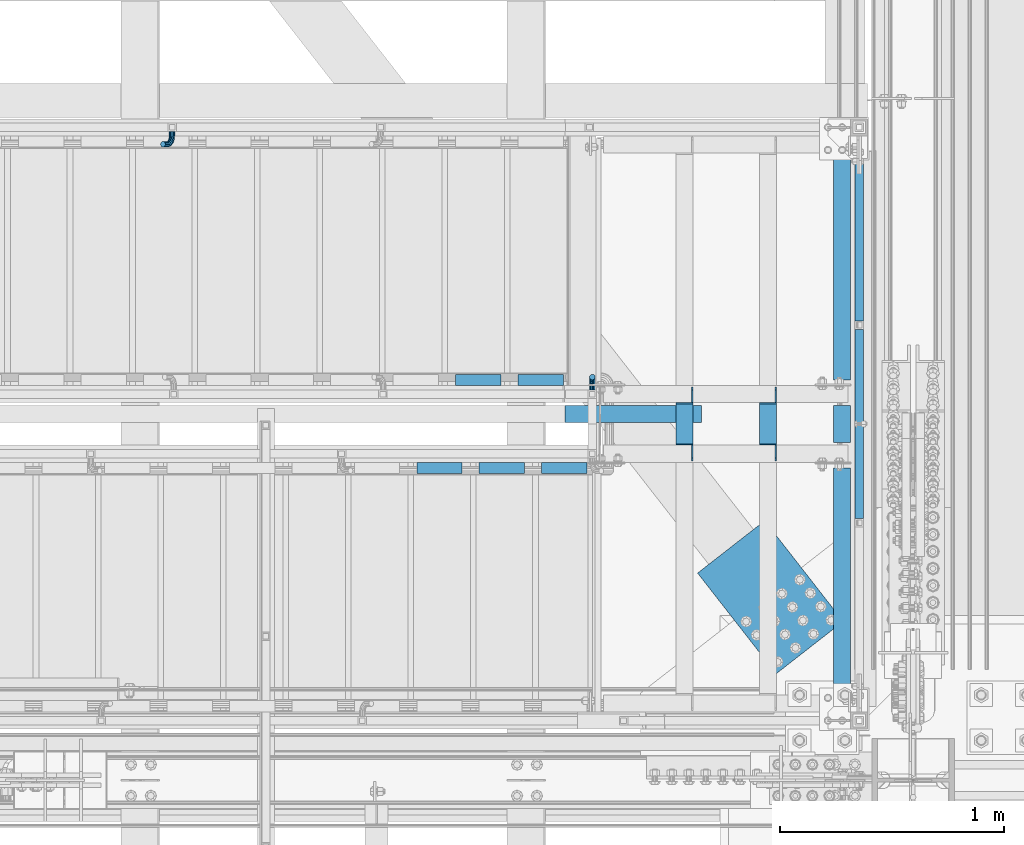
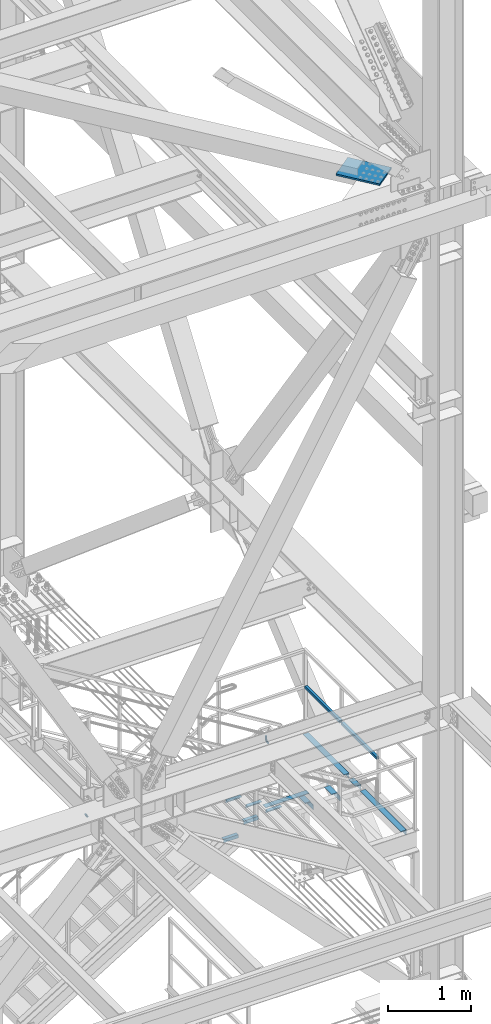
# One storey, part 2588 of 3843: 16 beams, 10 elements without a shape of their own.
"""IFC2X3 building model written with IfcOpenShell, lengths in millimetres."""

from ifc_helpers import new_model, si_unit, frame, origin_with_axes, place, context, subcontext, project, spatial, faceted_brep, material, type_object, element, aggregate, save


model = new_model("IFC2X3")

# Units and contexts
model_context = context("Model", 3, precision=1e-05, world=origin_with_axes())
body_context = subcontext(model_context, "Body", "Model", "MODEL_VIEW")
ifc_project = project(units=[si_unit("LENGTHUNIT", "METRE", prefix="MILLI"), si_unit("AREAUNIT", "SQUARE_METRE"), si_unit("VOLUMEUNIT", "CUBIC_METRE"), si_unit("MASSUNIT", "GRAM", prefix="KILO"), si_unit("TIMEUNIT", "SECOND"), si_unit("PLANEANGLEUNIT", "RADIAN"), si_unit("SOLIDANGLEUNIT", "STERADIAN"), si_unit("THERMODYNAMICTEMPERATUREUNIT", "DEGREE_CELSIUS"), si_unit("LUMINOUSINTENSITYUNIT", "LUMEN")], contexts=[model_context])

# Site, building, storey
site_placement = place(None, origin_with_axes())
site = spatial("IfcSite", under=ifc_project, at=site_placement, CompositionType="ELEMENT")
building_placement = place(site_placement, origin_with_axes())
building = spatial("IfcBuilding", under=site, at=building_placement, Name="Undefined", CompositionType="ELEMENT")
storey_placement = place(building_placement, origin_with_axes())
storey = spatial("IfcBuildingStorey", under=building, at=storey_placement, Name="Undefined", CompositionType="ELEMENT", Elevation=0.0)

# Assembly, beams
assembly_1_placement = place(storey_placement, origin_with_axes())
assembly_1 = element("IfcElementAssembly", 1, at=assembly_1_placement, inside=storey, Name="RAIL", AssemblyPlace="NOTDEFINED", PredefinedType="RIGID_FRAME")
ifc_material_1 = material()
beam_type_1 = type_object("IfcBeamType", Name="HSS1-1/2X1-1/2X1/4", PredefinedType="NOTDEFINED")
beam_1_placement = place(assembly_1_placement, frame((85407.4999999663, 17034.933333332, 33248.5999999989), z_axis=(0.0, 0.0, 1.0), x_axis=(0.0, 1.0, 0.0)))
beam_1 = element("IfcBeam", 2, at=beam_1_placement, type_object=beam_type_1, material=ifc_material_1, Name="RAIL", ObjectType="HSS1-1/2X1-1/2X1/4", context=body_context, shape_type="Brep", body=[
    faceted_brep([(865.716666687869, -19.0500000104294, 19.0499992350015), (865.716666687869, -19.0499992350015, -19.0499992350015), (865.716666687869, 19.0499992350015, -19.0499992350015), (865.716666687869, 19.0499992518344, 19.0499992350015), (865.716666687869, -12.6999993300014, 12.6999993299978), (865.716666687869, 12.6999993300014, 12.6999993299978), (865.716666687869, 12.6999993300014, -12.6999993299978), (865.716666687869, -12.6999993300014, -12.6999993299978), (19.0499992350015, 19.0499992350015, -19.0499992350015), (19.0499992350015, 19.0499992350015, 19.0499992350015), (19.0499992350015, -19.0499992350015, 19.0499992350015), (19.0499992350015, -19.0499992350015, -19.0499992350015), (19.0499992350015, 12.6999993299978, 12.6999993299978), (19.0499992350015, -12.6999993299978, 12.6999993299978), (19.0499992350015, -12.6999993299978, -12.6999993299978), (19.0499992350015, 12.6999993299978, -12.6999993299978)], [[[0, 1, 2, 3], [4, 5, 6, 7]], [[8, 9, 3, 2]], [[9, 10, 0, 3]], [[10, 11, 1, 0]], [[11, 8, 2, 1]], [[11, 10, 9, 8], [12, 13, 14, 15]], [[14, 13, 4, 7]], [[15, 14, 7, 6]], [[12, 15, 6, 5]], [[13, 12, 5, 4]]]),
])
beam_2_placement = place(assembly_1_placement, frame((85407.4999999681, 16150.1666666695, 33248.5999999989), z_axis=(0.0, 0.0, 1.0), x_axis=(0.0, 1.0, 0.0)))
beam_2 = element("IfcBeam", 3, at=beam_2_placement, type_object=beam_type_1, material=ifc_material_1, Name="RAIL", ObjectType="HSS1-1/2X1-1/2X1/4", context=body_context, shape_type="Brep", body=[
    faceted_brep([(865.716666687869, -19.0500000104294, 19.0499992350015), (865.716666687869, -19.0499992350015, -19.0499992350015), (865.716666687869, 19.0499992350015, -19.0499992350015), (865.716666687869, 19.0499992518344, 19.0499992350015), (865.716666687869, -12.6999993300014, 12.6999993299978), (865.716666687869, 12.6999993300014, 12.6999993299978), (865.716666687869, 12.6999993300014, -12.6999993299978), (865.716666687869, -12.6999993300014, -12.6999993299978), (19.0499992350015, 19.0499992350015, -19.0499992350015), (19.0499992350015, 19.0499992350015, 19.0499992350015), (19.0499992350015, -19.0499992350015, 19.0499992350015), (19.0499992350015, -19.0499992350015, -19.0499992350015), (19.0499992350015, 12.6999993299978, 12.6999993299978), (19.0499992350015, -12.6999993299978, 12.6999993299978), (19.0499992350015, -12.6999993299978, -12.6999993299978), (19.0499992350015, 12.6999993299978, -12.6999993299978)], [[[0, 1, 2, 3], [4, 5, 6, 7]], [[8, 9, 3, 2]], [[9, 10, 0, 3]], [[10, 11, 1, 0]], [[11, 8, 2, 1]], [[11, 10, 9, 8], [12, 13, 14, 15]], [[14, 13, 4, 7]], [[15, 14, 7, 6]], [[12, 15, 6, 5]], [[13, 12, 5, 4]]]),
])
aggregate(assembly_1, [beam_1, beam_2])

# Assembly, beam
assembly_2_placement = place(storey_placement, origin_with_axes())
assembly_2 = element("IfcElementAssembly", 4, at=assembly_2_placement, inside=storey, Name="ref.", AssemblyPlace="NOTDEFINED", PredefinedType="RIGID_FRAME")
ifc_material_2 = material(Name="STEEL/Steel_Undefined")
beam_type_2 = type_object("IfcBeamType", PredefinedType="NOTDEFINED")
beam_3_placement = place(assembly_2_placement, frame((84092.2107283887, 16637.0, 32712.0249999846), z_axis=(0.0, 1.0, 0.0), x_axis=(1.0, 0.0, 0.0)))
beam_3 = element("IfcBeam", 5, at=beam_3_placement, type_object=beam_type_2, material=ifc_material_2, Name="ref.", context=body_context, shape_type="Brep", body=[
    faceted_brep([(0.0, 3.17500000000291, -38.0999999999985), (0.0, 3.17500000000291, 38.0999999999985), (609.600000000006, 3.17499999999927, 38.0999999999985), (609.600000000006, 3.17499999999927, -38.0999999999985), (0.0, -3.17500000000291, 38.0999999999985), (609.600000000006, -3.17499999999927, 38.0999999999985), (0.0, -3.17500000000291, -38.0999999999985), (609.600000000006, -3.17499999999927, -38.0999999999985)], [[[0, 1, 2, 3]], [[1, 4, 5, 2]], [[4, 6, 7, 5]], [[6, 0, 3, 7]], [[5, 7, 3, 2]], [[6, 4, 1, 0]]]),
])
aggregate(assembly_2, [beam_3])

assembly_3_placement = place(storey_placement, origin_with_axes())
assembly_3 = element("IfcElementAssembly", 6, at=assembly_3_placement, inside=storey, Name="STAIR", AssemblyPlace="NOTDEFINED", PredefinedType="RIGID_FRAME")
ifc_material_3 = material(Name="STEEL/A572-50")
beam_type_3 = type_object("IfcBeamType", Name="L2X2X3/16", PredefinedType="NOTDEFINED")
beam_4_placement = place(assembly_3_placement, frame((84084.7140030485, 16789.3999999329, 32463.8865384615), z_axis=(0.0, 1.0, 0.0), x_axis=(-1.0, 0.0, 0.0)))
beam_4 = element("IfcBeam", 7, at=beam_4_placement, type_object=beam_type_3, material=ifc_material_3, Name="ANGLE", ObjectType="L2X2X3/16", context=body_context, shape_type="Brep", body=[
    faceted_brep([(0.0, 25.4000000000015, -25.4000000000015), (0.0, 25.4000000000015, 25.4000000000015), (203.199999999997, 25.4000000000015, 25.4000000000015), (203.199999999997, 25.4000000000015, -25.4000000000015), (0.0, 20.6375000000007, 25.4000000000015), (203.199999999997, 20.6375000000007, 25.4000000000015), (0.0, 20.6375000000007, -20.6375000000007), (203.199999999997, 20.6375000000007, -20.6375000000007), (0.0, -25.4000000000015, -20.6375000000007), (203.199999999997, -25.4000000000015, -20.6375000000007), (0.0, -25.4000000000015, -25.4000000000015), (203.199999999997, -25.4000000000015, -25.4000000000015)], [[[0, 1, 2, 3]], [[1, 4, 5, 2]], [[4, 6, 7, 5]], [[6, 8, 9, 7]], [[8, 10, 11, 9]], [[10, 0, 3, 11]], [[5, 7, 9, 11, 3, 2]], [[10, 8, 6, 4, 1, 0]]]),
])

# Assembly, beams
assembly_4_placement = place(storey_placement, origin_with_axes())
assembly_4 = element("IfcElementAssembly", 8, at=assembly_4_placement, inside=storey, Name="STAIR", AssemblyPlace="NOTDEFINED", PredefinedType="RIGID_FRAME")
ifc_material_4 = material(Name="STEEL/A36")
beam_5_placement = place(assembly_4_placement, frame((83428.2859969491, 16395.700000067, 33151.6403846146), z_axis=(0.0, -1.0, 0.0), x_axis=(1.0, 0.0, 0.0)))
beam_5 = element("IfcBeam", 9, at=beam_5_placement, type_object=beam_type_3, material=ifc_material_4, Name="ANGLE", ObjectType="L2X2X3/16", context=body_context, shape_type="Brep", body=[
    faceted_brep([(0.0, 25.4000000000015, -25.4000000000015), (0.0, 25.4000000000015, 25.4000000000015), (203.199999999997, 25.4000000000015, 25.4000000000015), (203.199999999997, 25.4000000000015, -25.4000000000015), (0.0, 20.6375000000007, 25.4000000000015), (203.199999999997, 20.6375000000007, 25.4000000000015), (0.0, 20.6375000000007, -20.6375000000007), (203.199999999997, 20.6375000000007, -20.6375000000007), (0.0, -25.4000000000015, -20.6375000000007), (203.199999999997, -25.4000000000015, -20.6375000000007), (0.0, -25.4000000000015, -25.4000000000015), (203.199999999997, -25.4000000000015, -25.4000000000015)], [[[0, 1, 2, 3]], [[1, 4, 5, 2]], [[4, 6, 7, 5]], [[6, 8, 9, 7]], [[8, 10, 11, 9]], [[10, 0, 3, 11]], [[5, 7, 9, 11, 3, 2]], [[10, 8, 6, 4, 1, 0]]]),
])
beam_6_placement = place(assembly_4_placement, frame((83707.6859969491, 16395.700000067, 32979.7019230762), z_axis=(0.0, -1.0, 0.0), x_axis=(1.0, 0.0, 0.0)))
beam_6 = element("IfcBeam", 10, at=beam_6_placement, type_object=beam_type_3, material=ifc_material_4, Name="ANGLE", ObjectType="L2X2X3/16", context=body_context, shape_type="Brep", body=[
    faceted_brep([(0.0, 25.4000000000015, -25.4000000000015), (0.0, 25.4000000000015, 25.4000000000015), (203.199999999997, 25.4000000000015, 25.4000000000015), (203.199999999997, 25.4000000000015, -25.4000000000015), (0.0, 20.6375000000007, 25.4000000000015), (203.199999999997, 20.6375000000007, 25.4000000000015), (0.0, 20.6375000000007, -20.6375000000007), (203.199999999997, 20.6375000000007, -20.6375000000007), (0.0, -25.4000000000015, -20.6375000000007), (203.199999999997, -25.4000000000015, -20.6375000000007), (0.0, -25.4000000000015, -25.4000000000015), (203.199999999997, -25.4000000000015, -25.4000000000015)], [[[0, 1, 2, 3]], [[1, 4, 5, 2]], [[4, 6, 7, 5]], [[6, 8, 9, 7]], [[8, 10, 11, 9]], [[10, 0, 3, 11]], [[5, 7, 9, 11, 3, 2]], [[10, 8, 6, 4, 1, 0]]]),
])
beam_7_placement = place(assembly_4_placement, frame((83987.0859969491, 16395.700000067, 32807.7634615377), z_axis=(0.0, -1.0, 0.0), x_axis=(1.0, 0.0, 0.0)))
beam_7 = element("IfcBeam", 11, at=beam_7_placement, type_object=beam_type_3, material=ifc_material_4, Name="ANGLE", ObjectType="L2X2X3/16", context=body_context, shape_type="Brep", body=[
    faceted_brep([(0.0, 25.4000000000015, -25.4000000000015), (0.0, 25.4000000000015, 25.4000000000015), (203.199999999997, 25.4000000000015, 25.4000000000015), (203.199999999997, 25.4000000000015, -25.4000000000015), (0.0, 20.6375000000007, 25.4000000000015), (203.199999999997, 20.6375000000007, 25.4000000000015), (0.0, 20.6375000000007, -20.6375000000007), (203.199999999997, 20.6375000000007, -20.6375000000007), (0.0, -25.4000000000015, -20.6375000000007), (203.199999999997, -25.4000000000015, -20.6375000000007), (0.0, -25.4000000000015, -25.4000000000015), (203.199999999997, -25.4000000000015, -25.4000000000015)], [[[0, 1, 2, 3]], [[1, 4, 5, 2]], [[4, 6, 7, 5]], [[6, 8, 9, 7]], [[8, 10, 11, 9]], [[10, 0, 3, 11]], [[5, 7, 9, 11, 3, 2]], [[10, 8, 6, 4, 1, 0]]]),
])
aggregate(assembly_4, [beam_5, beam_6, beam_7])

# Beam
beam_8_placement = place(assembly_3_placement, frame((83805.3140030504, 16789.3999999318, 32291.9480769222), z_axis=(0.0, 1.0, 0.0), x_axis=(-1.0, 0.0, 0.0)))
beam_8 = element("IfcBeam", 12, at=beam_8_placement, type_object=beam_type_3, material=ifc_material_3, Name="ANGLE", ObjectType="L2X2X3/16", context=body_context, shape_type="Brep", body=[
    faceted_brep([(0.0, 25.4000000000015, -25.4000000000015), (0.0, 25.4000000000015, 25.4000000000015), (203.199999999997, 25.4000000000015, 25.4000000000015), (203.199999999997, 25.4000000000015, -25.4000000000015), (0.0, 20.6375000000007, 25.4000000000015), (203.199999999997, 20.6375000000007, 25.4000000000015), (0.0, 20.6375000000007, -20.6375000000007), (203.199999999997, 20.6375000000007, -20.6375000000007), (0.0, -25.4000000000015, -20.6375000000007), (203.199999999997, -25.4000000000015, -20.6375000000007), (0.0, -25.4000000000015, -25.4000000000015), (203.199999999997, -25.4000000000015, -25.4000000000015)], [[[0, 1, 2, 3]], [[1, 4, 5, 2]], [[4, 6, 7, 5]], [[6, 8, 9, 7]], [[8, 10, 11, 9]], [[10, 0, 3, 11]], [[5, 7, 9, 11, 3, 2]], [[10, 8, 6, 4, 1, 0]]]),
])

aggregate(assembly_3, [beam_4, beam_8])

# Assembly, beam
assembly_5_placement = place(storey_placement, origin_with_axes())
assembly_5 = element("IfcElementAssembly", 13, at=assembly_5_placement, inside=storey, Name="RAIL", AssemblyPlace="NOTDEFINED", PredefinedType="RIGID_FRAME")
beam_type_4 = type_object("IfcBeamType", PredefinedType="NOTDEFINED")
beam_9_placement = place(assembly_5_placement, frame((82332.8664563633, 17900.65, 32430.6618078464), z_axis=(-0.851658316635875, 0.0, -0.524097425775922), x_axis=(0.0, -1.0, 0.0)))
beam_9 = element("IfcBeam", 14, at=beam_9_placement, type_object=beam_type_4, material=ifc_material_4, Name="BRACKET ARM", context=body_context, shape_type="Brep", body=[
    faceted_brep([(0.0, -12.6999999999971, 0.0), (0.0, -10.9985226280696, -6.34999999999854), (19.0500015258731, -10.9985226280623, -6.34999999999854), (19.0500015258731, -12.6999999999971, -6.33008312433958e-10), (0.0, -6.35000000000582, -10.9985226280623), (19.0500015258731, -6.34999999999854, -10.9985226280623), (0.0, 0.0, -12.6999999999971), (19.0500015258731, 0.0, -12.6999999999971), (0.0, 6.35000000000582, -10.9985226280623), (19.0500015258731, 6.34999999999854, -10.9985226280623), (0.0, 10.9985226280696, -6.34999999999854), (19.0500015258731, 10.9985226280623, -6.34999999999854), (0.0, 12.6999999999971, 0.0), (19.0500015258731, 12.6999999999971, 0.0), (0.0, 10.9985226280696, 6.34999999999854), (19.0500015258731, 10.9985226280623, 6.34999999999854), (0.0, 6.35000000000582, 10.9985226280623), (19.0500015258731, 6.34999999999854, 10.9985226280623), (0.0, 0.0, 12.6999999999971), (19.0500015258731, 0.0, 12.6999999999971), (0.0, -6.35000000000582, 10.9985226280623), (19.0500015258731, -6.34999999999854, 10.9985226280623), (0.0, -10.9985226280696, 6.34999999999854), (19.0500015258731, -10.9985226280623, 6.34999999999854), (38.4903193060891, -8.8330803677236, -3.34694050252438e-10), (37.8391921052389, -7.26112024908798, 6.34999999974389), (36.0602795104642, -2.96644533684594, 10.9985226280041), (33.6302397149266, 2.90018969451194, 12.7000000002226), (31.2001999194181, 8.76682472604443, 10.9985226285644), (29.4212873247307, 13.061499638774, 6.35000000070431), (28.7701601240115, 14.6334597580644, 7.78527464717627e-10), (29.4212873248762, 13.0614996394288, -6.34999999929278), (31.2001999196509, 8.76682472718676, -10.9985226275603), (33.6302397151885, 2.90018969582889, -12.6999999997788), (36.0602795106824, -2.96644533571089, -10.9985226281206), (37.8391921053699, -7.26112024843314, -6.35000000026048), (53.7678987435793, 3.38210125690239, -6.3499999994383), (54.9710249311902, 2.17897506880399, 5.0931703299284e-10), (50.4808968708676, 6.66910312997061, -10.9985226273784), (45.9907688103704, 11.1592311906061, -12.6999999991458), (41.5006407498004, 15.6493592510378, -10.9985226270364), (38.213638876914, 18.9363611235749, -6.34999999884167), (37.0105126890558, 20.1394873109457, 1.20053300634027e-09), (38.2136388766667, 18.9363611228473, 6.35000000115542), (41.5006407493784, 15.6493592497718, 10.9985226290883), (45.9907688098756, 11.1592311891436, 12.7000000008557), (50.4808968704456, 6.66910312870459, 10.9985226287463), (53.7678987433319, 3.38210125617479, 6.35000000055879), (64.4111202489148, 19.3108078951118, -6.34999999821594), (65.9830803677178, 18.6596806939051, 1.77533365786076e-09), (60.1164453365491, 21.0897204901557, -10.9985226262725), (54.2498103051475, 23.5197602857806, -12.6999999981927), (48.3831752736587, 25.9498000811873, -10.9985226262434), (44.0885003610601, 27.7287126756128, -6.34999999817228), (42.516540241937, 28.3798398759754, 1.83354131877422e-09), (44.08850036074, 27.7287126747688, 6.35000000183209), (48.3831752731057, 25.9498000797321, 10.9985226298813), (54.2498103045073, 23.5197602840999, 12.7000000018088), (60.1164453359961, 21.0897204886933, 10.9985226298522), (64.4111202485947, 19.3108078942678, 6.35000000178115), (68.1485226282239, 38.0999984746086, -6.3499999967753), (69.8499999999913, 38.0999984741211, 2.92493496090174e-09), (63.500000000291, 38.0999984749651, -10.9985226249628), (57.1500000003434, 38.0999984750961, -12.6999999970722), (50.8000000002939, 38.0999984749651, -10.998522625312), (46.1514773720992, 38.0999984746086, -6.34999999737192), (44.4499999999971, 38.0999984741211, 2.58296495303512e-09), (46.1514773717645, 38.0999984736336, 6.35000000262517), (50.7999999996973, 38.0999984732771, 10.9985226308127), (57.1499999996449, 38.0999984731461, 12.700000002922), (63.4999999996944, 38.0999984732771, 10.9985226311619), (68.1485226278892, 38.0999984736336, 6.35000000322179), (68.1485226280638, 76.2000000002372, -6.34999999414867), (69.8499999999913, 76.199999999757, 5.84986992180347e-09), (63.5, 76.200000000601, -10.9985226222125), (57.1499999999942, 76.2000000007247, -12.6999999941472), (50.7999999999884, 76.200000000601, -10.9985226222125), (46.1514773719246, 76.2000000002372, -6.34999999414867), (44.4499999999971, 76.199999999757, 5.84986992180347e-09), (46.1514773719246, 76.1999999992695, 6.35000000584841), (50.7999999999884, 76.1999999989057, 10.9985226339122), (57.1499999999942, 76.199999998782, 12.700000005847), (63.5, 76.1999999989057, 10.9985226339122), (68.1485226280638, 76.1999999992695, 6.35000000584841)], [[[0, 1, 2, 3]], [[1, 4, 5, 2]], [[4, 6, 7, 5]], [[6, 8, 9, 7]], [[8, 10, 11, 9]], [[10, 12, 13, 11]], [[12, 14, 15, 13]], [[14, 16, 17, 15]], [[16, 18, 19, 17]], [[18, 20, 21, 19]], [[20, 22, 23, 21]], [[22, 0, 3, 23]], [[22, 20, 18, 16, 14, 12, 10, 8, 6, 4, 1, 0]], [[23, 3, 24, 25]], [[21, 23, 25, 26]], [[19, 21, 26, 27]], [[17, 19, 27, 28]], [[15, 17, 28, 29]], [[13, 15, 29, 30]], [[11, 13, 30, 31]], [[9, 11, 31, 32]], [[7, 9, 32, 33]], [[5, 7, 33, 34]], [[2, 5, 34, 35]], [[3, 2, 35, 24]], [[35, 36, 37, 24]], [[34, 38, 36, 35]], [[33, 39, 38, 34]], [[32, 40, 39, 33]], [[31, 41, 40, 32]], [[30, 42, 41, 31]], [[29, 43, 42, 30]], [[28, 44, 43, 29]], [[27, 45, 44, 28]], [[26, 46, 45, 27]], [[25, 47, 46, 26]], [[24, 37, 47, 25]], [[36, 48, 49, 37]], [[38, 50, 48, 36]], [[39, 51, 50, 38]], [[40, 52, 51, 39]], [[41, 53, 52, 40]], [[42, 54, 53, 41]], [[43, 55, 54, 42]], [[44, 56, 55, 43]], [[45, 57, 56, 44]], [[46, 58, 57, 45]], [[47, 59, 58, 46]], [[37, 49, 59, 47]], [[48, 60, 61, 49]], [[50, 62, 60, 48]], [[51, 63, 62, 50]], [[52, 64, 63, 51]], [[53, 65, 64, 52]], [[54, 66, 65, 53]], [[55, 67, 66, 54]], [[56, 68, 67, 55]], [[57, 69, 68, 56]], [[58, 70, 69, 57]], [[59, 71, 70, 58]], [[49, 61, 71, 59]], [[61, 60, 72, 73]], [[60, 62, 74, 72]], [[62, 63, 75, 74]], [[63, 64, 76, 75]], [[64, 65, 77, 76]], [[65, 66, 78, 77]], [[66, 67, 79, 78]], [[67, 68, 80, 79]], [[68, 69, 81, 80]], [[69, 70, 82, 81]], [[70, 71, 83, 82]], [[71, 61, 73, 83]], [[74, 75, 76, 77, 78, 79, 80, 81, 82, 83, 73, 72]]]),
])
aggregate(assembly_5, [beam_9])

assembly_6_placement = place(storey_placement, origin_with_axes())
assembly_6 = element("IfcElementAssembly", 15, at=assembly_6_placement, inside=storey, Name="RAIL", AssemblyPlace="NOTDEFINED", PredefinedType="RIGID_FRAME")
beam_10_placement = place(assembly_6_placement, frame((84213.6999994719, 16744.95, 33534.35), z_axis=(1.0, 0.0, 0.0), x_axis=(0.0, 1.0, 0.0)))
beam_10 = element("IfcBeam", 16, at=beam_10_placement, type_object=beam_type_4, material=ifc_material_4, Name="BRACKET ARM", context=body_context, shape_type="Brep", body=[
    faceted_brep([(0.0, -12.6999999999971, 0.0), (0.0, -10.9985226280696, -6.34999999999854), (19.0500015258731, -10.9985226280623, -6.34999999999854), (19.0500015258731, -12.6999999999971, -6.33008312433958e-10), (0.0, -6.35000000000582, -10.9985226280623), (19.0500015258731, -6.34999999999854, -10.9985226280623), (0.0, 0.0, -12.6999999999971), (19.0500015258731, 0.0, -12.6999999999971), (0.0, 6.35000000000582, -10.9985226280623), (19.0500015258731, 6.34999999999854, -10.9985226280623), (0.0, 10.9985226280696, -6.34999999999854), (19.0500015258731, 10.9985226280623, -6.34999999999854), (0.0, 12.6999999999971, 0.0), (19.0500015258731, 12.6999999999971, 0.0), (0.0, 10.9985226280696, 6.34999999999854), (19.0500015258731, 10.9985226280623, 6.34999999999854), (0.0, 6.35000000000582, 10.9985226280623), (19.0500015258731, 6.34999999999854, 10.9985226280623), (0.0, 0.0, 12.6999999999971), (19.0500015258731, 0.0, 12.6999999999971), (0.0, -6.35000000000582, 10.9985226280623), (19.0500015258731, -6.34999999999854, 10.9985226280623), (0.0, -10.9985226280696, 6.34999999999854), (19.0500015258731, -10.9985226280623, 6.34999999999854), (38.4903193060891, -8.8330803677236, -3.34694050252438e-10), (37.8391921052389, -7.26112024908798, 6.34999999974389), (36.0602795104642, -2.96644533684594, 10.9985226280041), (33.6302397149266, 2.90018969451194, 12.7000000002226), (31.2001999194181, 8.76682472604443, 10.9985226285644), (29.4212873247307, 13.061499638774, 6.35000000070431), (28.7701601240115, 14.6334597580644, 7.78527464717627e-10), (29.4212873248762, 13.0614996394288, -6.34999999929278), (31.2001999196509, 8.76682472718676, -10.9985226275603), (33.6302397151885, 2.90018969582889, -12.6999999997788), (36.0602795106824, -2.96644533571089, -10.9985226281206), (37.8391921053699, -7.26112024843314, -6.35000000026048), (53.7678987435793, 3.38210125690239, -6.3499999994383), (54.9710249311902, 2.17897506880399, 5.0931703299284e-10), (50.4808968708676, 6.66910312997061, -10.9985226273784), (45.9907688103704, 11.1592311906061, -12.6999999991458), (41.5006407498004, 15.6493592510378, -10.9985226270364), (38.213638876914, 18.9363611235749, -6.34999999884167), (37.0105126890558, 20.1394873109457, 1.20053300634027e-09), (38.2136388766667, 18.9363611228473, 6.35000000115542), (41.5006407493784, 15.6493592497718, 10.9985226290883), (45.9907688098756, 11.1592311891436, 12.7000000008557), (50.4808968704456, 6.66910312870459, 10.9985226287463), (53.7678987433319, 3.38210125617479, 6.35000000055879), (64.4111202489148, 19.3108078951118, -6.34999999821594), (65.9830803677178, 18.6596806939051, 1.77533365786076e-09), (60.1164453365491, 21.0897204901557, -10.9985226262725), (54.2498103051475, 23.5197602857806, -12.6999999981927), (48.3831752736587, 25.9498000811873, -10.9985226262434), (44.0885003610601, 27.7287126756128, -6.34999999817228), (42.516540241937, 28.3798398759754, 1.83354131877422e-09), (44.08850036074, 27.7287126747688, 6.35000000183209), (48.3831752731057, 25.9498000797321, 10.9985226298813), (54.2498103045073, 23.5197602840999, 12.7000000018088), (60.1164453359961, 21.0897204886933, 10.9985226298522), (64.4111202485947, 19.3108078942678, 6.35000000178115), (68.1485226282239, 38.0999984746086, -6.3499999967753), (69.8499999999913, 38.0999984741211, 2.92493496090174e-09), (63.500000000291, 38.0999984749651, -10.9985226249628), (57.1500000003434, 38.0999984750961, -12.6999999970722), (50.8000000002939, 38.0999984749651, -10.998522625312), (46.1514773720992, 38.0999984746086, -6.34999999737192), (44.4499999999971, 38.0999984741211, 2.58296495303512e-09), (46.1514773717645, 38.0999984736336, 6.35000000262517), (50.7999999996973, 38.0999984732771, 10.9985226308127), (57.1499999996449, 38.0999984731461, 12.700000002922), (63.4999999996944, 38.0999984732771, 10.9985226311619), (68.1485226278892, 38.0999984736336, 6.35000000322179), (68.1485226280638, 76.2000000002372, -6.34999999414867), (69.8499999999913, 76.199999999757, 5.84986992180347e-09), (63.5, 76.200000000601, -10.9985226222125), (57.1499999999942, 76.2000000007247, -12.6999999941472), (50.7999999999884, 76.200000000601, -10.9985226222125), (46.1514773719246, 76.2000000002372, -6.34999999414867), (44.4499999999971, 76.199999999757, 5.84986992180347e-09), (46.1514773719246, 76.1999999992695, 6.35000000584841), (50.7999999999884, 76.1999999989057, 10.9985226339122), (57.1499999999942, 76.199999998782, 12.700000005847), (63.5, 76.1999999989057, 10.9985226339122), (68.1485226280638, 76.1999999992695, 6.35000000584841)], [[[0, 1, 2, 3]], [[1, 4, 5, 2]], [[4, 6, 7, 5]], [[6, 8, 9, 7]], [[8, 10, 11, 9]], [[10, 12, 13, 11]], [[12, 14, 15, 13]], [[14, 16, 17, 15]], [[16, 18, 19, 17]], [[18, 20, 21, 19]], [[20, 22, 23, 21]], [[22, 0, 3, 23]], [[22, 20, 18, 16, 14, 12, 10, 8, 6, 4, 1, 0]], [[23, 3, 24, 25]], [[21, 23, 25, 26]], [[19, 21, 26, 27]], [[17, 19, 27, 28]], [[15, 17, 28, 29]], [[13, 15, 29, 30]], [[11, 13, 30, 31]], [[9, 11, 31, 32]], [[7, 9, 32, 33]], [[5, 7, 33, 34]], [[2, 5, 34, 35]], [[3, 2, 35, 24]], [[35, 36, 37, 24]], [[34, 38, 36, 35]], [[33, 39, 38, 34]], [[32, 40, 39, 33]], [[31, 41, 40, 32]], [[30, 42, 41, 31]], [[29, 43, 42, 30]], [[28, 44, 43, 29]], [[27, 45, 44, 28]], [[26, 46, 45, 27]], [[25, 47, 46, 26]], [[24, 37, 47, 25]], [[36, 48, 49, 37]], [[38, 50, 48, 36]], [[39, 51, 50, 38]], [[40, 52, 51, 39]], [[41, 53, 52, 40]], [[42, 54, 53, 41]], [[43, 55, 54, 42]], [[44, 56, 55, 43]], [[45, 57, 56, 44]], [[46, 58, 57, 45]], [[47, 59, 58, 46]], [[37, 49, 59, 47]], [[48, 60, 61, 49]], [[50, 62, 60, 48]], [[51, 63, 62, 50]], [[52, 64, 63, 51]], [[53, 65, 64, 52]], [[54, 66, 65, 53]], [[55, 67, 66, 54]], [[56, 68, 67, 55]], [[57, 69, 68, 56]], [[58, 70, 69, 57]], [[59, 71, 70, 58]], [[49, 61, 71, 59]], [[61, 60, 72, 73]], [[60, 62, 74, 72]], [[62, 63, 75, 74]], [[63, 64, 76, 75]], [[64, 65, 77, 76]], [[65, 66, 78, 77]], [[66, 67, 79, 78]], [[67, 68, 80, 79]], [[68, 69, 81, 80]], [[69, 70, 82, 81]], [[70, 71, 83, 82]], [[71, 61, 73, 83]], [[74, 75, 76, 77, 78, 79, 80, 81, 82, 83, 73, 72]]]),
])
aggregate(assembly_6, [beam_10])

# Assembly, beams
assembly_7_placement = place(storey_placement, origin_with_axes())
assembly_7 = element("IfcElementAssembly", 17, at=assembly_7_placement, inside=storey, Name="STRINGER", AssemblyPlace="NOTDEFINED", PredefinedType="RIGID_FRAME")
beam_type_5 = type_object("IfcBeamType", Name="L3X3X1/4", PredefinedType="NOTDEFINED")
beam_11_placement = place(assembly_7_placement, frame((85331.3000000149, 16395.7000004497, 32626.2999999982), z_axis=(-1.0, 0.0, 0.0), x_axis=(0.0, -1.0, 0.0)))
beam_11 = element("IfcBeam", 18, at=beam_11_placement, type_object=beam_type_5, material=ifc_material_4, Name="ANGLE", ObjectType="L3X3X1/4", context=body_context, shape_type="Brep", body=[
    faceted_brep([(0.0, 38.0999999999985, -38.0999999999985), (0.0, 38.0999999999985, 38.0999999999985), (990.600000450311, 38.0999999999985, 38.1000000000058), (990.600000450311, 38.0999999999985, -38.1000000000058), (0.0, 31.75, 38.0999999999985), (990.600000450311, 31.75, 38.1000000000058), (0.0, 31.75, -31.75), (990.600000450311, 31.75, -31.75), (0.0, -38.0999999999985, -31.75), (990.600000450311, -38.0999999999985, -31.75), (0.0, -38.0999999999985, -38.0999999999985), (990.600000450311, -38.0999999999985, -38.1000000000058)], [[[0, 1, 2, 3]], [[1, 4, 5, 2]], [[4, 6, 7, 5]], [[6, 8, 9, 7]], [[8, 10, 11, 9]], [[10, 0, 3, 11]], [[5, 7, 9, 11, 3, 2]], [[10, 8, 6, 4, 1, 0]]]),
])
beam_12_placement = place(assembly_7_placement, frame((85331.3000000149, 16675.0999984059, 32626.2999999983), z_axis=(-1.0, 0.0, 0.0), x_axis=(0.0, -1.0, 0.0)))
beam_12 = element("IfcBeam", 19, at=beam_12_placement, type_object=beam_type_5, material=ifc_material_4, Name="ANGLE", ObjectType="L3X3X1/4", context=body_context, shape_type="Brep", body=[
    faceted_brep([(0.0, 38.0999999999985, -38.0999999999985), (0.0, 38.0999999999985, 38.0999999999985), (165.099996811728, 38.0999999999985, 38.1000000000058), (165.099996811728, 38.0999999999985, -38.1000000000058), (0.0, 31.75, 38.0999999999985), (165.099996811728, 31.75, 38.1000000000058), (0.0, 31.75, -31.75), (165.099996811728, 31.75, -31.75), (0.0, -38.0999999999985, -31.75), (165.099996811728, -38.0999999999985, -31.75), (0.0, -38.0999999999985, -38.0999999999985), (165.099996811728, -38.0999999999985, -38.1000000000058)], [[[0, 1, 2, 3]], [[1, 4, 5, 2]], [[4, 6, 7, 5]], [[6, 8, 9, 7]], [[8, 10, 11, 9]], [[10, 0, 3, 11]], [[5, 7, 9, 11, 3, 2]], [[10, 8, 6, 4, 1, 0]]]),
])

# Assembly, beam
assembly_8_placement = place(storey_placement, origin_with_axes())
assembly_8 = element("IfcElementAssembly", 20, at=assembly_8_placement, inside=storey, Name="ANGLE", AssemblyPlace="NOTDEFINED", PredefinedType="RIGID_FRAME")
beam_13_placement = place(assembly_8_placement, frame((84998.9833333429, 16763.9999999318, 32626.2999999982), z_axis=(-1.0, 0.0, 0.0), x_axis=(0.0, -1.0, 0.0)))
beam_13 = element("IfcBeam", 21, at=beam_13_placement, type_object=beam_type_5, material=ifc_material_4, Name="ANGLE", ObjectType="L3X3X1/4", context=body_context, shape_type="Brep", body=[
    faceted_brep([(6.34999999941647, -38.0999999999985, -31.75), (6.34999999999854, 19.0499999999956, -31.75), (6.34999999999854, 19.0499999999956, -38.0999999999985), (6.34999999941647, -38.0999999999985, -38.0999999999985), (19.0500000000029, 31.75, -31.75), (19.0499999999956, 31.7499999999927, -38.0999999999985), (76.1999999999971, 31.75, -31.75), (76.1999999999971, 31.7499999999927, -38.0999999999985), (82.5500000005923, 38.0999999999985, 38.0999999999985), (82.5499948264696, 38.0999999999458, -38.0999999999985), (76.1999999999971, 31.75, 38.0999999999985), (336.549999862917, -38.099999999944, -31.75), (336.549999862917, -38.0999999999985, -38.1000000000058), (336.549999863502, 19.0500000000429, -38.1000000000058), (336.549999863502, 19.0500000000429, -31.75), (323.849999863502, 31.7500000000437, -38.1000000000058), (323.849999863502, 31.75, -31.75), (266.699999863504, 31.7500000000437, -38.1000000000058), (266.699999863504, 31.75, -31.75), (266.699999863504, 31.75, 38.1000000000058), (260.349999862909, 38.0999999999985, -38.1000000000058), (260.349999862909, 38.0999999999985, 38.1000000000058)], [[[0, 1, 2, 3]], [[4, 5, 2, 1]], [[6, 7, 5, 4]], [[8, 9, 7, 6, 10]], [[11, 12, 13, 14]], [[14, 13, 15, 16]], [[16, 15, 17, 18]], [[19, 18, 17, 20, 21]], [[19, 21, 8, 10]], [[18, 19, 10, 6]], [[1, 0, 11, 14, 16, 18, 6, 4]], [[12, 11, 0, 3]], [[20, 17, 15, 13, 12, 3, 2, 5, 7, 9]], [[21, 20, 9, 8]]]),
])
aggregate(assembly_8, [beam_13])

assembly_9_placement = place(storey_placement, origin_with_axes())
assembly_9 = element("IfcElementAssembly", 22, at=assembly_9_placement, inside=storey, Name="ANGLE", AssemblyPlace="NOTDEFINED", PredefinedType="RIGID_FRAME")
beam_14_placement = place(assembly_9_placement, frame((84626.4500000046, 16763.9999999318, 32626.2999999982), z_axis=(-1.0, 0.0, 0.0), x_axis=(0.0, -1.0, 0.0)))
beam_14 = element("IfcBeam", 23, at=beam_14_placement, type_object=beam_type_5, material=ifc_material_4, Name="ANGLE", ObjectType="L3X3X1/4", context=body_context, shape_type="Brep", body=[
    faceted_brep([(6.34999999941647, -38.0999999999985, -31.75), (6.34999999999854, 19.0499999999956, -31.75), (6.34999999999854, 19.0499999999956, -38.0999999999985), (6.34999999941647, -38.0999999999985, -38.0999999999985), (19.0500000000029, 31.75, -31.75), (19.0499999999956, 31.7499999999927, -38.0999999999985), (76.1999999999971, 31.75, -31.75), (76.1999999999971, 31.7499999999927, -38.0999999999985), (82.5500000005923, 38.0999999999985, 38.0999999999985), (82.5499948264696, 38.0999999999458, -38.0999999999985), (76.1999999999971, 31.75, 38.0999999999985), (336.549999862917, -38.099999999944, -31.75), (336.549999862917, -38.0999999999985, -38.1000000000058), (336.549999863502, 19.0500000000429, -38.1000000000058), (336.549999863502, 19.0500000000429, -31.75), (323.849999863502, 31.7500000000437, -38.1000000000058), (323.849999863502, 31.75, -31.75), (266.699999863504, 31.7500000000437, -38.1000000000058), (266.699999863504, 31.75, -31.75), (266.699999863504, 31.75, 38.1000000000058), (260.349999862909, 38.0999999999985, -38.1000000000058), (260.349999862909, 38.0999999999985, 38.1000000000058)], [[[0, 1, 2, 3]], [[4, 5, 2, 1]], [[6, 7, 5, 4]], [[8, 9, 7, 6, 10]], [[11, 12, 13, 14]], [[14, 13, 15, 16]], [[16, 15, 17, 18]], [[19, 18, 17, 20, 21]], [[19, 21, 8, 10]], [[18, 19, 10, 6]], [[1, 0, 11, 14, 16, 18, 6, 4]], [[12, 11, 0, 3]], [[20, 17, 15, 13, 12, 3, 2, 5, 7, 9]], [[21, 20, 9, 8]]]),
])
aggregate(assembly_9, [beam_14])

# Beam
beam_15_placement = place(assembly_7_placement, frame((85331.3000000151, 17780.0000000006, 32626.2999999983), z_axis=(-1.0, 0.0, 0.0), x_axis=(0.0, -1.0, 0.0)))
beam_15 = element("IfcBeam", 24, at=beam_15_placement, type_object=beam_type_5, material=ifc_material_4, Name="ANGLE", ObjectType="L3X3X1/4", context=body_context, shape_type="Brep", body=[
    faceted_brep([(0.0, 38.0999999999985, -38.0999999999985), (0.0, 38.0999999999985, 38.0999999999985), (990.600000450311, 38.0999999999985, 38.1000000000058), (990.600000450311, 38.0999999999985, -38.1000000000058), (0.0, 31.75, 38.0999999999985), (990.600000450311, 31.75, 38.1000000000058), (0.0, 31.75, -31.75), (990.600000450311, 31.75, -31.75), (0.0, -38.0999999999985, -31.75), (990.600000450311, -38.0999999999985, -31.75), (0.0, -38.0999999999985, -38.0999999999985), (990.600000450311, -38.0999999999985, -38.1000000000058)], [[[0, 1, 2, 3]], [[1, 4, 5, 2]], [[4, 6, 7, 5]], [[6, 8, 9, 7]], [[8, 10, 11, 9]], [[10, 0, 3, 11]], [[5, 7, 9, 11, 3, 2]], [[10, 8, 6, 4, 1, 0]]]),
])

aggregate(assembly_7, [beam_11, beam_12, beam_15])

# Assembly, beam
assembly_10_placement = place(storey_placement, origin_with_axes())
assembly_10 = element("IfcElementAssembly", 25, at=assembly_10_placement, inside=storey, AssemblyPlace="NOTDEFINED", PredefinedType="RIGID_FRAME")
beam_type_6 = type_object("IfcBeamType", PredefinedType="NOTDEFINED")
beam_16_placement = place(assembly_10_placement, frame((85186.1696816928, 15591.888566003, 42259.25), z_axis=(0.788538898871981, 0.614984881900168, 0.0), x_axis=(-0.614984883006892, 0.788538898008842, 0.0)))
beam_16 = element("IfcBeam", 26, at=beam_16_placement, type_object=beam_type_6, material=ifc_material_3, Name="PLATE", context=body_context, shape_type="Brep", body=[
    faceted_brep([(5.85714587941766e-10, 12.6999999999971, -190.500000000349), (-6.14818418398499e-10, 12.6999999999971, 190.500000000364), (571.499999996191, 12.6999999999971, 190.49999999936), (571.499999997392, 12.6999999999971, -190.500000001353), (-6.14818418398499e-10, -12.6999999999971, 190.500000000364), (571.499999996191, -12.6999999999971, 190.49999999936), (5.85714587941766e-10, -12.6999999999971, -190.500000000349), (571.499999997392, -12.6999999999971, -190.500000001353)], [[[0, 1, 2, 3]], [[1, 4, 5, 2]], [[4, 6, 7, 5]], [[6, 0, 3, 7]], [[5, 7, 3, 2]], [[6, 4, 1, 0]]]),
])
aggregate(assembly_10, [beam_16])

save(model, "model.ifc")
